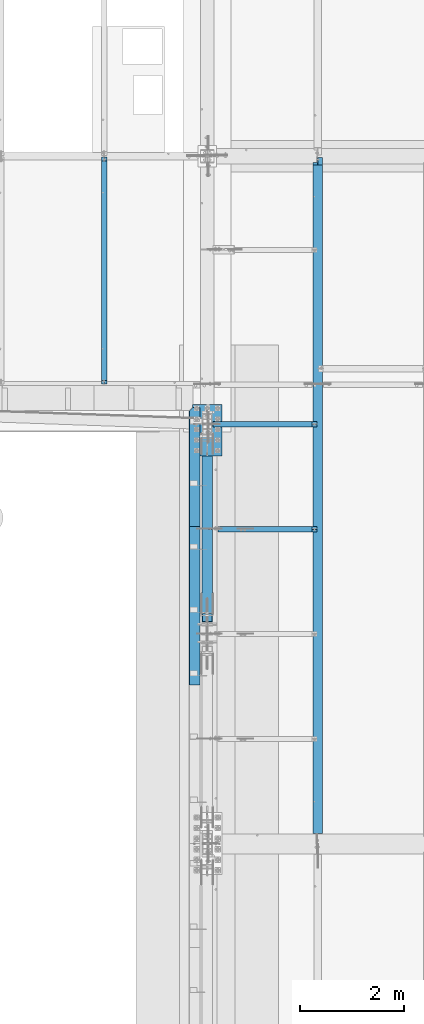
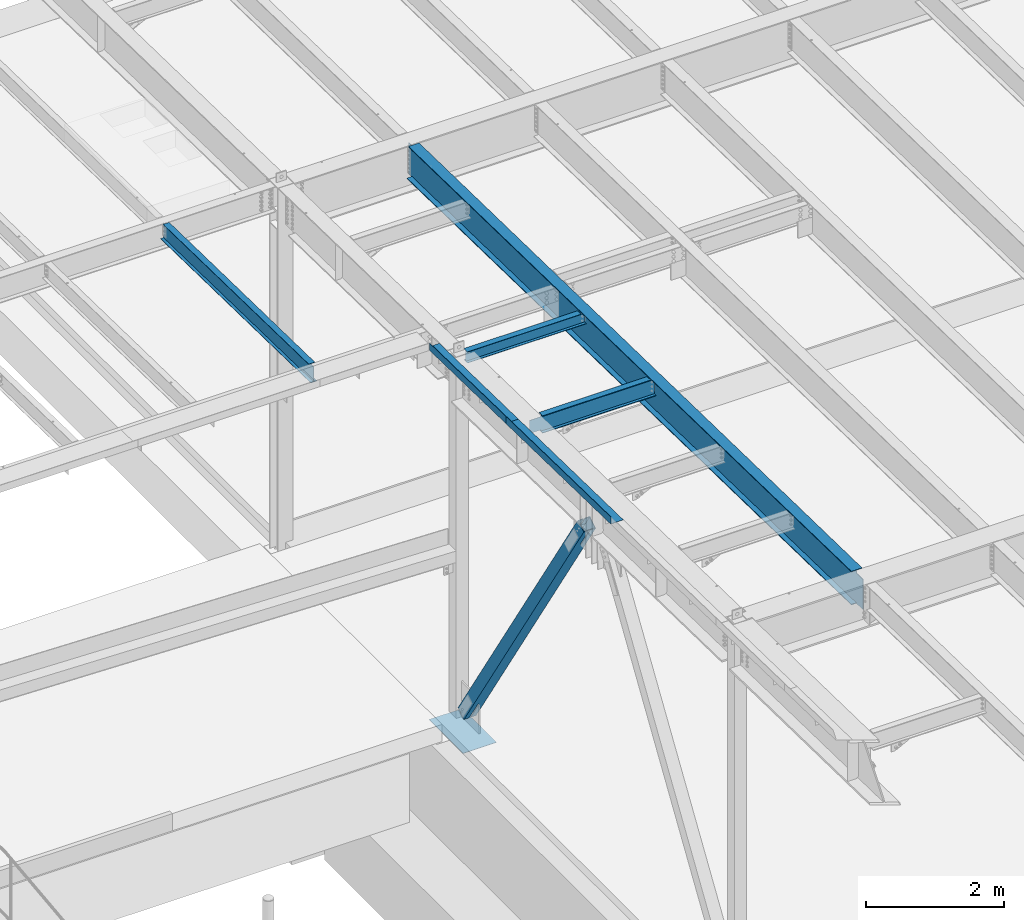
# One storey, part 1048 of 1763: 7 beams, 1 member, 7 elements without a shape of their own.
"""IFC2X3 building model written with IfcOpenShell, lengths in millimetres."""

from ifc_helpers import new_model, si_unit, frame, origin_with_axes, place, context, subcontext, project, spatial, faceted_brep, material, type_object, element, aggregate, save


model = new_model("IFC2X3")

# Units and contexts
model_context = context("Model", 3, precision=1e-05, world=origin_with_axes())
body_context = subcontext(model_context, "Body", "Model", "MODEL_VIEW")
ifc_project = project(units=[si_unit("LENGTHUNIT", "METRE", prefix="MILLI"), si_unit("AREAUNIT", "SQUARE_METRE"), si_unit("VOLUMEUNIT", "CUBIC_METRE"), si_unit("MASSUNIT", "GRAM", prefix="KILO"), si_unit("TIMEUNIT", "SECOND"), si_unit("PLANEANGLEUNIT", "RADIAN"), si_unit("SOLIDANGLEUNIT", "STERADIAN"), si_unit("THERMODYNAMICTEMPERATUREUNIT", "DEGREE_CELSIUS"), si_unit("LUMINOUSINTENSITYUNIT", "LUMEN")], contexts=[model_context])

# Site, building, storey
site_placement = place(None, origin_with_axes())
site = spatial("IfcSite", under=ifc_project, at=site_placement, CompositionType="ELEMENT")
building_placement = place(site_placement, origin_with_axes())
building = spatial("IfcBuilding", under=site, at=building_placement, Name="Undefined", CompositionType="ELEMENT")
storey_placement = place(building_placement, origin_with_axes())
storey = spatial("IfcBuildingStorey", under=building, at=storey_placement, Name="Undefined", CompositionType="ELEMENT", Elevation=0.0)

# Assembly, beam
assembly_1_placement = place(storey_placement, origin_with_axes())
assembly_1 = element("IfcElementAssembly", 1, at=assembly_1_placement, inside=storey, Name="BEAM", AssemblyPlace="NOTDEFINED", PredefinedType="RIGID_FRAME")
ifc_material_1 = material(Name="STEEL/A992")
beam_type_1 = type_object("IfcBeamType", Name="W8X10", PredefinedType="NOTDEFINED")
beam_1_placement = place(assembly_1_placement, frame((-87375.4372736983, 8534.40000000001, 11623.5920365109), z_axis=(0.0, 0.0, 1.0), x_axis=(1.0, 0.0, 0.0)))
beam_1 = element("IfcBeam", 2, at=beam_1_placement, type_object=beam_type_1, material=ifc_material_1, Name="BEAM", ObjectType="W8X10", context=body_context, shape_type="Brep", body=[
    faceted_brep([(2019.98035714286, -50.7999999999993, 100.012500000001), (2019.98035714286, -50.7999999999993, 95.25), (2019.98035714286, -2.38125000000036, 95.25), (2019.98035714286, -2.38125000000036, 74.3525014843581), (2019.98035714286, 2.38125000000036, 74.3525014843581), (2019.98035714286, 2.38125000000036, 95.25), (2019.98035714286, 50.7999999999993, 95.25), (2019.98035714286, 50.7999999999993, 100.012500000001), (2020.94708706545, -2.38125000000036, 69.4924219663117), (2020.94708706545, 2.38125000000036, 69.4924219663117), (2023.70010096593, -2.38125000000036, 65.372245498158), (2023.70010096593, 2.38125000000036, 65.372245498158), (2027.82027743409, -2.38125000000036, 62.6192315976805), (2027.82027743409, 2.38125000000036, 62.6192315976805), (2032.68035695213, -2.38125000000036, 61.6525016750929), (2032.68035695213, 2.38125000000036, 61.6525016750929), (2108.88035714286, -2.38125000000036, 61.6525016750929), (2108.88035714286, 2.38125000000036, 61.6525016750929), (114.300000000003, -50.7999999999993, -100.012500000001), (114.300000000003, -50.7999999999993, -95.25), (114.300000000003, -2.38125000000036, -95.25), (114.300000000003, -2.38125000000036, 95.25), (114.300000000003, -50.7999999999993, 95.25), (114.300000000003, -50.7999999999993, 100.012500000001), (114.300000000003, 50.7999999999993, 100.012500000001), (114.300000000003, 50.7999999999993, 95.25), (114.300000000003, 2.38125000000036, 95.25), (114.300000000003, 2.38125000000036, -95.25), (114.300000000003, 50.7999999999993, -95.25), (114.300000000003, 50.7999999999993, -100.012500000001), (2108.88035714286, 2.38125000000036, -95.25), (2108.88035714286, 50.7999999999993, -95.25), (2108.88035714286, 50.7999999999993, -100.012500000001), (2108.88035714286, -50.7999999999993, -100.012500000001), (2108.88035714286, -50.7999999999993, -95.25), (2108.88035714286, -2.38125000000036, -95.25)], [[[0, 1, 2, 3, 4, 5, 6, 7]], [[8, 9, 4, 3]], [[10, 11, 9, 8]], [[12, 13, 11, 10]], [[14, 15, 13, 12]], [[16, 17, 15, 14]], [[18, 19, 20, 21, 22, 23, 24, 25, 26, 27, 28, 29]], [[28, 27, 30, 31]], [[29, 28, 31, 32]], [[18, 29, 32, 33]], [[19, 18, 33, 34]], [[20, 19, 34, 35]], [[12, 10, 8, 3, 2, 21, 20, 35, 16, 14]], [[22, 21, 2, 1]], [[23, 22, 1, 0]], [[24, 23, 0, 7]], [[25, 24, 7, 6]], [[26, 25, 6, 5]], [[30, 27, 26, 5, 4, 9, 11, 13, 15, 17]], [[35, 34, 33, 32, 31, 30, 17, 16]]]),
])
aggregate(assembly_1, [beam_1])

# Assembly, beams
assembly_2_placement = place(storey_placement, origin_with_axes())
assembly_2 = element("IfcElementAssembly", 3, at=assembly_2_placement, inside=storey, Name="BEAM", AssemblyPlace="NOTDEFINED", PredefinedType="RIGID_FRAME")
ifc_material_2 = material(Name="STEEL/A36")
beam_type_2 = type_object("IfcBeamType", PredefinedType="NOTDEFINED")
beam_2_placement = place(assembly_2_placement, frame((-87515.1372736983, 7710.01207617403, 11759.9451341199), z_axis=(0.0, -0.999781542838788, 0.0209013539966307), x_axis=(-1.0, 0.0, 0.0)))
beam_2 = element("IfcBeam", 4, at=beam_2_placement, type_object=beam_type_2, material=ifc_material_2, Name="BENT_PLATE", context=body_context, shape_type="Brep", body=[
    faceted_brep([(209.549993905966, -123.825003588479, -1072.07835102781), (203.199987793007, -123.825003588478, -1078.26001157983), (203.199987793021, -3.17499999970642, -1080.78231127025), (133.349999999264, -3.1749999996573, -1148.78049999988), (133.486367871039, 3.17500000034852, -1148.78049999988), (209.549987793027, 3.17500000029213, -1074.73340332958), (0.0, -3.17499999960455, -1148.78049999988), (0.0, -3.17500000040491, 1148.78049999988), (0.0, 3.17499999960091, 1148.78049999988), (0.0, 3.17500000040127, -1148.78049999988), (209.549987792998, 3.17499999951906, 1148.78049999988), (203.199987792992, -3.17500000048494, 1148.78049999988), (203.199987793007, -123.825003589222, 1148.78049999984), (209.549987793012, -123.825003589222, 1148.78049999984)], [[[0, 1, 2, 3, 4, 5]], [[6, 7, 8, 9]], [[10, 8, 7, 11, 12, 13]], [[10, 13, 0, 5]], [[9, 8, 10, 5, 4]], [[6, 9, 4, 3]], [[11, 7, 6, 3, 2]], [[12, 11, 2, 1]], [[13, 12, 1, 0]]]),
])
beam_3_placement = place(assembly_2_placement, frame((-87515.1372736983, 5037.81546432632, 11815.809870851), z_axis=(0.0, -0.999781542838788, 0.0209013539966307), x_axis=(-1.0, 0.0, 0.0)))
beam_3 = element("IfcBeam", 5, at=beam_3_placement, type_object=beam_type_2, material=ifc_material_2, Name="BENT_PLATE", context=body_context, shape_type="Brep", body=[
    faceted_brep([(0.0, -3.17499999999927, -1523.99999999999), (0.0, -3.17499999999927, 1524.0), (0.0, 3.17499999999927, 1524.0), (0.0, 3.17499999999927, -1523.99999999999), (209.549987792998, 3.174999999379, 1523.99999999984), (209.549987793027, 3.17500000043947, -1523.99999999984), (203.199987793021, -3.17499999956271, -1523.99999999984), (203.199987792992, -3.17500000062137, 1523.99999999984), (209.549987793012, -123.825003589356, 1523.99999999986), (209.549987793012, -123.825003588337, -1523.99999999982), (203.199987793007, -123.825003589356, 1523.99999999986), (203.199987793007, -123.825003588337, -1523.99999999982)], [[[0, 1, 2, 3]], [[3, 2, 4, 5]], [[1, 0, 6, 7]], [[5, 4, 8, 9]], [[4, 2, 1, 7, 10, 8]], [[7, 6, 11, 10]], [[6, 0, 3, 5, 9, 11]], [[10, 11, 9, 8]]]),
])
aggregate(assembly_2, [beam_2, beam_3])

# Assembly, beam
assembly_3_placement = place(storey_placement, origin_with_axes())
assembly_3 = element("IfcElementAssembly", 6, at=assembly_3_placement, inside=storey, Name="BEAM", AssemblyPlace="NOTDEFINED", PredefinedType="RIGID_FRAME")
beam_type_3 = type_object("IfcBeamType", Name="W12X22", PredefinedType="NOTDEFINED")
beam_4_placement = place(assembly_3_placement, frame((-87375.4372736983, 6515.09999998665, 11626.1751802778), z_axis=(0.0, 0.0, 1.0), x_axis=(1.0, 0.0, 0.0)))
beam_4 = element("IfcBeam", 7, at=beam_4_placement, type_object=beam_type_3, material=ifc_material_1, Name="BEAM", ObjectType="W12X22", context=body_context, shape_type="Brep", body=[
    faceted_brep([(20.6374999999971, -3.17499999999927, -123.824999999781), (20.6374999999971, 3.17499999999927, -123.824999999781), (198.437500190732, 3.17500001932785, -123.824999999781), (198.437500190732, -3.17500000000018, -123.824999999781), (203.297579708771, 3.17500001940971, -124.791729922368), (203.297579708771, -3.17500000000018, -124.791729922368), (207.417756176932, 3.17500001964163, -127.544743822846), (207.417756176932, -3.17500000000018, -127.544743822846), (210.170770077413, 3.17500001998906, -131.664920290999), (210.170770077413, -3.17500000000018, -131.664920290999), (211.137499999997, -3.17500000000018, -136.524999809046), (211.137499999997, 3.17500002039924, -136.524999809046), (211.137499999997, 3.17500004775593, -144.4625), (211.137499999997, 50.8000000000002, -144.4625), (211.137499999997, 50.8000000000002, -155.575000000001), (211.137499999997, -50.8000000000002, -155.575000000001), (211.137499999997, -50.8000000000002, -144.4625), (211.137499999997, -3.17500000000018, -144.4625), (2019.98035714286, 50.7999999999993, 144.4625), (2019.98035714286, 3.17499999999927, 144.4625), (211.137499999997, 3.17500000000018, 144.4625), (211.137499999997, 50.8000000000002, 144.4625), (198.437500190732, -3.17500000000018, 111.12500000022), (198.437500190732, 3.17499999968732, 111.12500000022), (20.6374999999971, 3.17499999999927, 111.12500000022), (20.6374999999971, -3.17499999999927, 111.12500000022), (203.297579708771, -3.17500000000018, 112.091729922808), (203.297579708771, 3.17499999960637, 112.091729922808), (207.417756176932, -3.17500000000018, 114.844743823285), (207.417756176932, 3.17499999937718, 114.844743823285), (210.170770077413, -3.17500000000018, 118.964920291439), (210.170770077413, 3.1749999990343, 118.964920291439), (211.137499999997, -3.17500000000018, 123.824999809485), (211.137499999997, 3.17499999862866, 123.824999809485), (2019.98035714286, -50.7999999999993, 155.575000000001), (2019.98035714286, 50.7999999999993, 155.575000000001), (211.137499999997, 50.8000000000002, 155.575000000001), (211.137499999997, -50.8000000000002, 155.575000000001), (2019.98035714286, -50.7999999999993, 144.4625), (211.137499999997, -50.8000000000002, 144.4625), (2019.98035714286, -3.17499999999927, 144.4625), (211.137499999997, -3.17500000000018, 144.4625), (2019.98035714286, -3.17499999999927, 129.915001480787), (2019.98035714286, 3.17499999999927, 129.915001480787), (2020.94708706545, -3.17499999999927, 125.054921962741), (2020.94708706545, 3.17499999999927, 125.054921962741), (2023.70010096593, -3.17499999999927, 120.934745494587), (2023.70010096593, 3.17499999999927, 120.934745494587), (2027.82027743409, -3.17499999999927, 118.18173159411), (2027.82027743409, 3.17499999999927, 118.18173159411), (2032.68035695213, -3.17499999999927, 117.215001671522), (2032.68035695213, 3.17499999999927, 117.215001671522), (2108.88035714286, -3.17499999999927, 117.215001671522), (2108.88035714286, 3.17499999999927, 117.215001671522), (2108.88035714286, -3.17499999999927, -144.4625), (2108.88035714286, -50.7999999999993, -144.4625), (2108.88035714286, -50.7999999999993, -155.575000000001), (2108.88035714286, 50.7999999999993, -155.575000000001), (2108.88035714286, 50.7999999999993, -144.4625), (2108.88035714286, 3.17499999999927, -144.4625)], [[[0, 1, 2, 3]], [[3, 2, 4, 5]], [[5, 4, 6, 7]], [[7, 6, 8, 9]], [[10, 11, 12, 13, 14, 15, 16, 17]], [[9, 8, 11, 10]], [[18, 19, 20, 21]], [[22, 23, 24, 25]], [[26, 27, 23, 22]], [[28, 29, 27, 26]], [[30, 31, 29, 28]], [[32, 33, 31, 30]], [[34, 35, 36, 37]], [[38, 34, 37, 39]], [[40, 38, 39, 41]], [[37, 36, 21, 20, 33, 32, 41, 39]], [[35, 18, 21, 36]], [[34, 38, 40, 42, 43, 19, 18, 35]], [[44, 45, 43, 42]], [[46, 47, 45, 44]], [[48, 49, 47, 46]], [[50, 51, 49, 48]], [[52, 53, 51, 50]], [[54, 55, 56, 57, 58, 59, 53, 52]], [[55, 54, 17, 16]], [[56, 55, 16, 15]], [[57, 56, 15, 14]], [[58, 57, 14, 13]], [[59, 58, 13, 12]], [[6, 4, 2, 1, 24, 23, 27, 29, 31, 33, 20, 19, 43, 45, 47, 49, 51, 53, 59, 12, 11, 8]], [[25, 24, 1, 0]], [[54, 52, 50, 48, 46, 44, 42, 40, 41, 32, 30, 28, 26, 22, 25, 0, 3, 5, 7, 9, 10, 17]]]),
])
aggregate(assembly_3, [beam_4])

assembly_4_placement = place(storey_placement, origin_with_axes())
assembly_4 = element("IfcElementAssembly", 8, at=assembly_4_placement, inside=storey, Name="BEAM", AssemblyPlace="NOTDEFINED", PredefinedType="RIGID_FRAME")
beam_type_4 = type_object("IfcBeamType", Name="W12X14", PredefinedType="NOTDEFINED")
beam_5_placement = place(assembly_4_placement, frame((-89356.6372736983, 9293.3022635624, 11571.2363541104), z_axis=(0.0, 0.0205403160093265, 0.999789025453989), x_axis=(0.0, 0.999789025516018, -0.0205403129900748)))
beam_5 = element("IfcBeam", 9, at=beam_5_placement, type_object=beam_type_4, material=ifc_material_1, Name="BEAM", ObjectType="W12X14", context=body_context, shape_type="Brep", body=[
    faceted_brep([(63.4267402376645, -2.38125000000582, 118.802501678683), (63.4267402376645, 2.38125000000582, 118.802501678683), (16.5359841821955, 2.38125000000582, 118.802501678665), (16.5359841821955, -2.38125000000582, 118.802501678665), (68.2868197557164, -2.38125000000582, 119.769231601276), (68.2868197557164, 2.38125000000582, 119.769231601276), (72.4069962238773, -2.38125000000582, 122.522245501759), (72.4069962238773, 2.38125000000582, 122.522245501759), (75.1600101243566, -2.38125000000582, 126.642421969918), (75.1600101243566, 2.38125000000582, 126.642421969918), (76.1267400469424, -2.38125000000582, 131.502501487972), (76.1267400469424, 2.38125000000582, 131.502501487972), (76.1267400469405, -2.38125000000582, 136.119267252339), (76.1267400469405, 2.38125000000582, 136.119267252339), (21.9446716062448, -2.38125000000582, -144.462500000054), (21.9446716062448, -50.8000000000029, -144.462500000054), (4384.52131423219, -50.8000000000029, -144.462499998235), (4384.52131423219, -2.38125000000582, -144.462499998235), (22.0751301363343, -50.8000000000029, -150.812500000056), (4384.65177276228, -50.8000000000029, -150.812499998237), (22.0751301363343, 50.8000000000029, -150.812500000056), (4384.65177276228, 50.8000000000029, -150.812499998237), (21.9446716062448, 50.8000000000029, -144.462500000054), (4384.52131423219, 50.8000000000029, -144.462499998235), (21.9446716062448, 2.38125000000582, -144.462500000054), (4384.52131423219, 2.38125000000582, -144.462499998235), (4379.11262680761, 2.38125000000582, 118.802501706059), (4379.11262680761, -2.38125000000582, 118.802501706059), (4318.05338248514, 2.38125000000582, 118.802501706034), (4318.05338248514, -2.38125000000582, 118.802501706034), (4313.19330296709, 2.38125000000582, 119.769231628623), (4313.19330296709, -2.38125000000582, 119.769231628623), (4309.07312649893, 2.38125000000582, 122.5222455291), (4309.07312649893, -2.38125000000582, 122.5222455291), (4306.32011259844, 2.38125000000582, 126.642421997258), (4306.32011259844, -2.38125000000582, 126.642421997258), (4305.35338267585, 2.38125000000582, 131.50250151531), (4305.35338267585, -2.38125000000582, 131.50250151531), (4305.35338267584, -50.8000000000029, 150.812500001864), (4305.35338267585, -50.8000000000029, 144.462500001864), (4305.35338267585, -2.38125000000582, 144.462500001864), (4305.35338267585, 2.38125000000582, 144.462500001864), (4305.35338267585, 50.8000000000029, 144.462500001864), (4305.35338267584, 50.8000000000029, 150.812500001864), (76.3465351600425, 2.38125000000582, 144.462500000098), (76.3465351600425, 50.8000000000029, 144.462500000098), (76.2160766299548, 50.8000000000029, 150.8125000001), (76.2160766299548, -50.8000000000029, 150.8125000001), (76.3465351600425, -50.8000000000029, 144.462500000098), (76.3465351600425, -2.38125000000582, 144.462500000098), (76.477390486938, 2.38125000000582, 138.093186125223), (76.477390486938, -2.38125000000582, 138.093186125223)], [[[0, 1, 2, 3]], [[4, 5, 1, 0]], [[6, 7, 5, 4]], [[8, 9, 7, 6]], [[10, 11, 9, 8]], [[12, 13, 11, 10]], [[14, 15, 16, 17]], [[15, 18, 19, 16]], [[18, 20, 21, 19]], [[20, 22, 23, 21]], [[22, 24, 25, 23]], [[17, 16, 19, 21, 23, 25, 26, 27]], [[27, 26, 28, 29]], [[29, 28, 30, 31]], [[31, 30, 32, 33]], [[33, 32, 34, 35]], [[35, 34, 36, 37]], [[38, 39, 40, 37, 36, 41, 42, 43]], [[42, 41, 44, 45]], [[43, 42, 45, 46]], [[38, 43, 46, 47]], [[39, 38, 47, 48]], [[40, 39, 48, 49]], [[47, 46, 45, 44, 50, 51, 49, 48]], [[8, 6, 4, 0, 3, 14, 17, 27, 29, 31, 33, 35, 37, 40, 49, 51, 12, 10]], [[24, 22, 20, 18, 15, 14, 3, 2]], [[50, 44, 41, 36, 34, 32, 30, 28, 26, 25, 24, 2, 1, 5, 7, 9, 11, 13]], [[51, 50, 13, 12]]]),
])
aggregate(assembly_4, [beam_5])

assembly_5_placement = place(storey_placement, origin_with_axes())
assembly_5 = element("IfcElementAssembly", 10, at=assembly_5_placement, inside=storey, Name="BEAM", AssemblyPlace="NOTDEFINED", PredefinedType="RIGID_FRAME")
beam_type_5 = type_object("IfcBeamType", Name="W24X55", PredefinedType="NOTDEFINED")
beam_6_placement = place(assembly_5_placement, frame((-85249.0944165555, 450.92880941152, 11608.424216848), z_axis=(0.0, 0.0209013539966291, 0.999781542838788), x_axis=(0.0, 0.999781542776098, -0.0209013569953182)))
beam_6 = element("IfcBeam", 11, at=beam_6_placement, type_object=beam_type_5, material=ifc_material_1, Name="BEAM", ObjectType="W24X55", context=body_context, shape_type="Brep", body=[
    faceted_brep([(222.141409579197, -4.76174993514724, -300.037500000315), (221.87590435652, -4.76249999999709, -287.337500000305), (32.9216259333548, -4.76249999999709, -287.33750000024), (33.1871311560335, -4.76174993514724, -300.03750000025), (222.141409579011, -88.8999999999942, -300.037500000315), (221.875904356335, -88.8999999999942, -287.337500000303), (13070.3160381473, -88.8999999999942, 300.037499995717), (13070.3160381473, -88.8999999999942, 287.337499995707), (13070.3160381473, -4.76249999999709, 287.337499995707), (13070.3160381474, -4.76249999999709, 268.027501414879), (13070.3160381474, 4.76249999999709, 268.027501414879), (13070.3160381473, 4.76249999999709, 287.337499995707), (13070.3160381473, 88.8999999999942, 287.337499995707), (13070.3160381473, 88.8999999999942, 300.037499995717), (13071.2827680699, -4.76249999999709, 263.167421896822), (13071.2827680699, 4.76249999999709, 263.167421896822), (13074.0357819704, -4.76249999999709, 259.047245428657), (13074.0357819704, 4.76249999999709, 259.047245428657), (13078.1559584386, -4.76249999999709, 256.294231528167), (13078.1559584386, 4.76249999999709, 256.294231528167), (13083.0160379566, -4.76249999999709, 255.327501605576), (13083.0160379566, 4.76249999999709, 255.327501605576), (13217.3781810464, -4.76249999999709, 255.32750160553), (13217.3781810464, 4.76249999999709, 255.32750160553), (33.1871311560335, 4.76299991607084, -300.03750000025), (32.9216259333548, 4.76249999999709, -287.33750000024), (221.87590435652, 4.76249999999709, -287.337500000305), (222.141409579197, 4.76299991607084, -300.037500000315), (13127.4660345771, 5.0626322090975, -287.337500004771), (13127.4660345772, 5.06236486541457, -300.037500004782), (13127.4660261933, 88.8999999999942, -300.037500004782), (13127.4660261934, 88.8999999999942, -287.337500004771), (222.141409579011, 88.8999999999942, -300.037500000315), (221.875904356335, 88.8999999999942, -287.337500000303), (13228.7230938096, 4.76249999999709, -287.337500004809), (13228.7230938096, 5.06264233497495, -287.337500004809), (13228.9885990323, 5.06237501776195, -300.037500004817), (13228.7230938096, -4.76249999999709, -287.337500004809), (13228.7230938096, -88.8999999999942, -287.337500004809), (13228.9885990323, -88.8999999999942, -300.037500004817), (21.9695354978562, -4.76249999999709, 236.53750000016), (21.9695354978562, 4.76249999999709, 236.53750000016), (192.092009575197, -4.76249999999709, 236.537500000164), (192.092009575197, 4.76249999999709, 236.537500000164), (196.952089093243, -4.76249999999709, 237.504229922752), (196.952089093243, 4.76249999999709, 237.504229922752), (201.072265561397, -4.76249999999709, 240.257243823233), (201.072265561397, 4.76249999999709, 240.257243823233), (203.825279461873, -4.76249999999709, 244.377420291396), (203.825279461873, 4.76249999999709, 244.377420291396), (204.792009384458, -4.76249999999709, 249.237499809455), (204.792009384458, 4.76249999999709, 249.237499809455), (204.792009384414, 4.76249999999709, 287.33750000016), (204.792009384414, 88.8999999999942, 287.33750000016), (204.792009384414, 88.8999999999942, 300.03750000017), (204.792009384414, -88.8999999999942, 300.03750000017), (204.792009384414, -88.8999999999942, 287.33750000016), (204.792009384414, -4.76249999999709, 287.33750000016), (204.792009384425, -4.76249999999709, 278.065642990567)], [[[0, 1, 2, 3]], [[4, 5, 1, 0]], [[6, 7, 8, 9, 10, 11, 12, 13]], [[14, 15, 10, 9]], [[16, 17, 15, 14]], [[18, 19, 17, 16]], [[20, 21, 19, 18]], [[22, 23, 21, 20]], [[24, 25, 26, 27]], [[28, 29, 30, 31]], [[31, 30, 32, 33]], [[27, 26, 33, 32]], [[34, 35, 28, 31, 33, 26]], [[36, 29, 28, 35]], [[34, 23, 22, 37, 38, 39, 36, 35]], [[3, 24, 27, 32, 30, 29, 36, 39, 4, 0]], [[40, 41, 25, 24, 3, 2]], [[42, 43, 41, 40]], [[44, 45, 43, 42]], [[46, 47, 45, 44]], [[48, 49, 47, 46]], [[50, 51, 49, 48]], [[11, 10, 15, 17, 19, 21, 23, 34, 26, 25, 41, 43, 45, 47, 49, 51, 52]], [[12, 11, 52, 53]], [[13, 12, 53, 54]], [[6, 13, 54, 55]], [[7, 6, 55, 56]], [[8, 7, 56, 57]], [[55, 54, 53, 52, 51, 50, 58, 57, 56]], [[50, 48, 46, 44, 42, 40, 2, 1, 37, 22, 20, 18, 16, 14, 9, 8, 57, 58]], [[38, 37, 1, 5]], [[39, 38, 5, 4]]]),
])
aggregate(assembly_5, [beam_6])

assembly_6_placement = place(storey_placement, origin_with_axes())
assembly_6 = element("IfcElementAssembly", 12, at=assembly_6_placement, inside=storey, Name="TEMPLATE", AssemblyPlace="NOTDEFINED", PredefinedType="RIGID_FRAME")
beam_type_6 = type_object("IfcBeamType", PredefinedType="NOTDEFINED")
beam_7_placement = place(assembly_6_placement, frame((-87375.4372736983, 7924.80000000001, 5083.17500000001), z_axis=(-1.0, 0.0, 0.0), x_axis=(0.0, 1.0, 0.0)))
beam_7 = element("IfcBeam", 13, at=beam_7_placement, type_object=beam_type_6, material=ifc_material_2, Name="TEMPLATE", context=body_context, shape_type="Brep", body=[
    faceted_brep([(0.0, 3.17500000000018, -279.399999999994), (0.0, 3.17500000000018, 279.399999999994), (990.599999999999, 3.17500000000018, 279.399999999994), (990.599999999999, 3.17500000000018, -279.399999999994), (0.0, -3.17500000000018, 279.399999999994), (990.599999999999, -3.17500000000018, 279.399999999994), (0.0, -3.17500000000018, -279.399999999994), (990.599999999999, -3.17500000000018, -279.399999999994)], [[[0, 1, 2, 3]], [[1, 4, 5, 2]], [[4, 6, 7, 5]], [[6, 0, 3, 7]], [[5, 7, 3, 2]], [[6, 4, 1, 0]]]),
])
aggregate(assembly_6, [beam_7])

# Assembly, member
assembly_7_placement = place(storey_placement, origin_with_axes())
assembly_7 = element("IfcElementAssembly", 14, at=assembly_7_placement, inside=storey, Name="V. BRACE", AssemblyPlace="NOTDEFINED", PredefinedType="RIGID_FRAME")
ifc_material_3 = material()
member_type = type_object("IfcMemberType", Name="HSS8X8X1/2", PredefinedType="NOTDEFINED")
member_placement = place(assembly_7_placement, frame((-87375.4372736983, 8534.40000000028, 5130.80000000007), z_axis=(0.0, 0.842093564139254, 0.539331465089187), x_axis=(0.0, -0.539331465089187, 0.842093564139254)))
member = element("IfcMember", 15, at=member_placement, type_object=member_type, material=ifc_material_3, Name="V. BRACE", ObjectType="HSS8X8X1/2", context=body_context, shape_type="Brep", body=[
    faceted_brep([(6892.56540700128, 11.1124999999884, 101.599999993326), (6409.9653747763, 11.1124999999884, 101.59999999379), (6409.9653747763, 11.1124999999884, 88.8999999937951), (6892.56540700129, 11.1124999999884, 88.8999999933294), (6406.32031522901, 10.387452576193, 101.599999993796), (6406.320315229, 10.387452576193, 88.8999999937987), (6403.23018295524, 8.32269220252056, 101.599999993796), (6403.23018295524, 8.32269220252056, 88.8999999938023), (6401.16542258156, 5.23255992875784, 101.599999993799), (6401.16542258156, 5.23255992875784, 88.8999999938042), (6400.44037515777, 1.58750038145809, 101.599999993799), (6400.44037515777, 1.58750038145809, 88.8999999938042), (6400.44037515777, -1.58750076295109, 101.599999993799), (6400.44037515777, -1.58750076295109, 88.8999999938042), (6401.16542258156, -5.23256031025085, 101.599999993799), (6401.16542258156, -5.23256031025085, 88.8999999938042), (6403.23018295524, -8.32269258401357, 101.599999993796), (6403.23018295524, -8.32269258401357, 88.8999999938023), (6406.32031522901, -10.387452957686, 101.599999993796), (6406.320315229, -10.387452957686, 88.8999999937987), (6409.9653747763, -11.1125003814814, 101.59999999379), (6409.9653747763, -11.1125003814814, 88.8999999937951), (6892.56540700128, -11.1125003814814, 101.599999993326), (6892.56540700129, -11.1125003814814, 88.8999999933294), (6892.56540700142, 11.1124999999884, -88.9000000066062), (6409.96537477626, 11.1124999999884, -88.9000000061424), (6409.96537477626, 11.1124999999884, -101.600000006139), (6892.56540700143, 11.1124999999884, -101.600000006603), (6406.32031522897, 10.387452576193, -88.9000000061387), (6406.32031522897, 10.387452576193, -101.600000006132), (6403.2301829552, 8.32269220252056, -88.9000000061351), (6403.2301829552, 8.32269220252056, -101.600000006132), (6401.16542258153, 5.23255992875784, -88.9000000061351), (6401.16542258152, 5.23255992875784, -101.600000006129), (6400.44037515773, 1.58750038145809, -88.9000000061333), (6400.44037515773, 1.58750038145809, -101.600000006129), (6400.44037515773, -1.58750076295109, -88.9000000061333), (6400.44037515773, -1.58750076295109, -101.600000006129), (6401.16542258153, -5.23256031025085, -88.9000000061351), (6401.16542258152, -5.23256031025085, -101.600000006129), (6403.2301829552, -8.32269258401357, -88.9000000061351), (6403.2301829552, -8.32269258401357, -101.600000006132), (6406.32031522897, -10.387452957686, -88.9000000061387), (6406.32031522897, -10.387452957686, -101.600000006132), (6409.96537477626, -11.1125003814814, -88.9000000061424), (6409.96537477626, -11.1125003814814, -101.600000006139), (6892.56540700142, -11.1125003814814, -88.9000000066062), (6892.56540700143, -11.1125003814814, -101.600000006603), (441.206801267595, 88.8999999999942, 88.8999999995431), (441.206801267732, 88.8999999999942, -88.9000000003944), (6892.56540700142, 88.8999999999942, -88.9000000066062), (6892.56540700129, 88.8999999999942, 88.8999999933294), (6892.56540700129, -88.8999999999942, 88.8999999933294), (441.206801267595, -88.8999999999942, 88.8999999995431), (441.206801267595, -14.2875007629482, 88.8999999995431), (898.406804509324, -14.2875007629482, 88.8999999991029), (903.266884027371, -13.3207708403643, 88.8999999990992), (907.387060495527, -10.5677569398831, 88.8999999990956), (910.140074396006, -6.44758047172218, 88.899999999092), (911.106804318594, -1.58750095368305, 88.899999999092), (911.106804318594, 1.58750019072613, 88.899999999092), (910.140074396006, 6.44757970876526, 88.899999999092), (907.387060495527, 10.5677561769262, 88.8999999990956), (903.266884027371, 13.3207700774074, 88.8999999990992), (898.406804509324, 14.2874999999913, 88.8999999991029), (441.206801267595, 14.2874999999913, 88.8999999995431), (441.206801267732, -88.8999999999942, -88.9000000003944), (6892.56540700142, -88.8999999999942, -88.9000000066062), (441.206801267732, 14.2874999999913, -88.9000000003944), (898.406804509425, 14.2874999999913, -88.9000000008346), (903.266884027473, 13.3207700774074, -88.9000000008382), (907.387060495627, 10.5677561769262, -88.9000000008418), (910.140074396108, 6.44757970876526, -88.9000000008455), (911.106804318694, 1.58750019072613, -88.9000000008455), (911.106804318694, -1.58750095368305, -88.9000000008455), (910.140074396108, -6.44758047172218, -88.9000000008455), (907.387060495627, -10.5677569398831, -88.9000000008418), (903.266884027473, -13.3207708403643, -88.9000000008382), (898.406804509425, -14.2875007629482, -88.9000000008346), (441.206801267732, -14.2875007629482, -88.9000000003944), (441.206801267743, 14.2874999999913, -101.60000000039), (898.406804509432, 14.2874999999913, -101.600000000828), (903.266884027479, 13.3207700774074, -101.600000000833), (907.387060495635, 10.5677561769262, -101.600000000837), (910.140074396114, 6.44757970876526, -101.600000000839), (911.106804318702, 1.58750019072613, -101.600000000843), (911.106804318702, -1.58750095368305, -101.600000000843), (910.140074396114, -6.44758047172218, -101.600000000839), (907.387060495635, -10.5677569398831, -101.600000000837), (903.266884027479, -13.3207708403643, -101.600000000833), (898.406804509432, -14.2875007629482, -101.600000000828), (441.206801267743, -14.2875007629482, -101.60000000039), (441.206801267743, -101.600000000006, -101.60000000039), (441.206801267586, -101.600000000006, 101.59999999954), (441.206801267586, -14.2875007629482, 101.59999999954), (898.406804509316, -14.2875007629482, 101.5999999991), (903.266884027364, -13.3207708403643, 101.599999999095), (907.387060495519, -10.5677569398831, 101.599999999093), (910.140074395998, -6.44758047172218, 101.599999999089), (911.106804318586, -1.58750095368305, 101.599999999085), (911.106804318586, 1.58750019072613, 101.599999999085), (910.140074395998, 6.44757970876526, 101.599999999089), (907.387060495519, 10.5677561769262, 101.599999999093), (903.266884027364, 13.3207700774074, 101.599999999095), (898.406804509316, 14.2874999999913, 101.5999999991), (441.206801267586, 14.2874999999913, 101.59999999954), (441.206801267586, 101.600000000006, 101.59999999954), (441.206801267743, 101.600000000006, -101.60000000039), (6892.56540700128, 101.600000000006, 101.599999993326), (6892.56540700143, 101.600000000006, -101.600000006603), (6892.56540700143, -101.600000000006, -101.600000006603), (6892.56540700128, -101.600000000006, 101.599999993326)], [[[0, 1, 2, 3]], [[4, 5, 2, 1]], [[6, 7, 5, 4]], [[8, 9, 7, 6]], [[10, 11, 9, 8]], [[12, 13, 11, 10]], [[14, 15, 13, 12]], [[16, 17, 15, 14]], [[18, 19, 17, 16]], [[20, 21, 19, 18]], [[22, 23, 21, 20]], [[24, 25, 26, 27]], [[28, 29, 26, 25]], [[30, 31, 29, 28]], [[32, 33, 31, 30]], [[34, 35, 33, 32]], [[36, 37, 35, 34]], [[38, 39, 37, 36]], [[40, 41, 39, 38]], [[42, 43, 41, 40]], [[44, 45, 43, 42]], [[46, 47, 45, 44]], [[48, 49, 50, 51]], [[52, 53, 54, 55, 56, 57, 58, 59, 60, 61, 62, 63, 64, 65, 48, 51, 3, 2, 5, 7, 9, 11, 13, 15, 17, 19, 21, 23]], [[66, 53, 52, 67]], [[42, 40, 38, 36, 34, 32, 30, 28, 25, 24, 50, 49, 68, 69, 70, 71, 72, 73, 74, 75, 76, 77, 78, 79, 66, 67, 46, 44]], [[68, 80, 81, 69]], [[69, 81, 82, 70]], [[70, 82, 83, 71]], [[71, 83, 84, 72]], [[72, 84, 85, 73]], [[73, 85, 86, 74]], [[74, 86, 87, 75]], [[75, 87, 88, 76]], [[76, 88, 89, 77]], [[77, 89, 90, 78]], [[78, 90, 91, 79]], [[53, 66, 79, 91, 92, 93, 94, 54]], [[95, 55, 54, 94]], [[96, 56, 55, 95]], [[97, 57, 56, 96]], [[98, 58, 57, 97]], [[99, 59, 58, 98]], [[100, 60, 59, 99]], [[101, 61, 60, 100]], [[102, 62, 61, 101]], [[103, 63, 62, 102]], [[104, 64, 63, 103]], [[105, 65, 64, 104]], [[106, 107, 80, 68, 49, 48, 65, 105]], [[107, 106, 108, 109]], [[51, 50, 24, 27, 109, 108, 0, 3]], [[110, 92, 91, 90, 89, 88, 87, 86, 85, 84, 83, 82, 81, 80, 107, 109, 27, 26, 29, 31, 33, 35, 37, 39, 41, 43, 45, 47]], [[93, 92, 110, 111]], [[18, 16, 14, 12, 10, 8, 6, 4, 1, 0, 108, 106, 105, 104, 103, 102, 101, 100, 99, 98, 97, 96, 95, 94, 93, 111, 22, 20]], [[111, 110, 47, 46, 67, 52, 23, 22]]]),
])
aggregate(assembly_7, [member])

save(model, "model.ifc")
